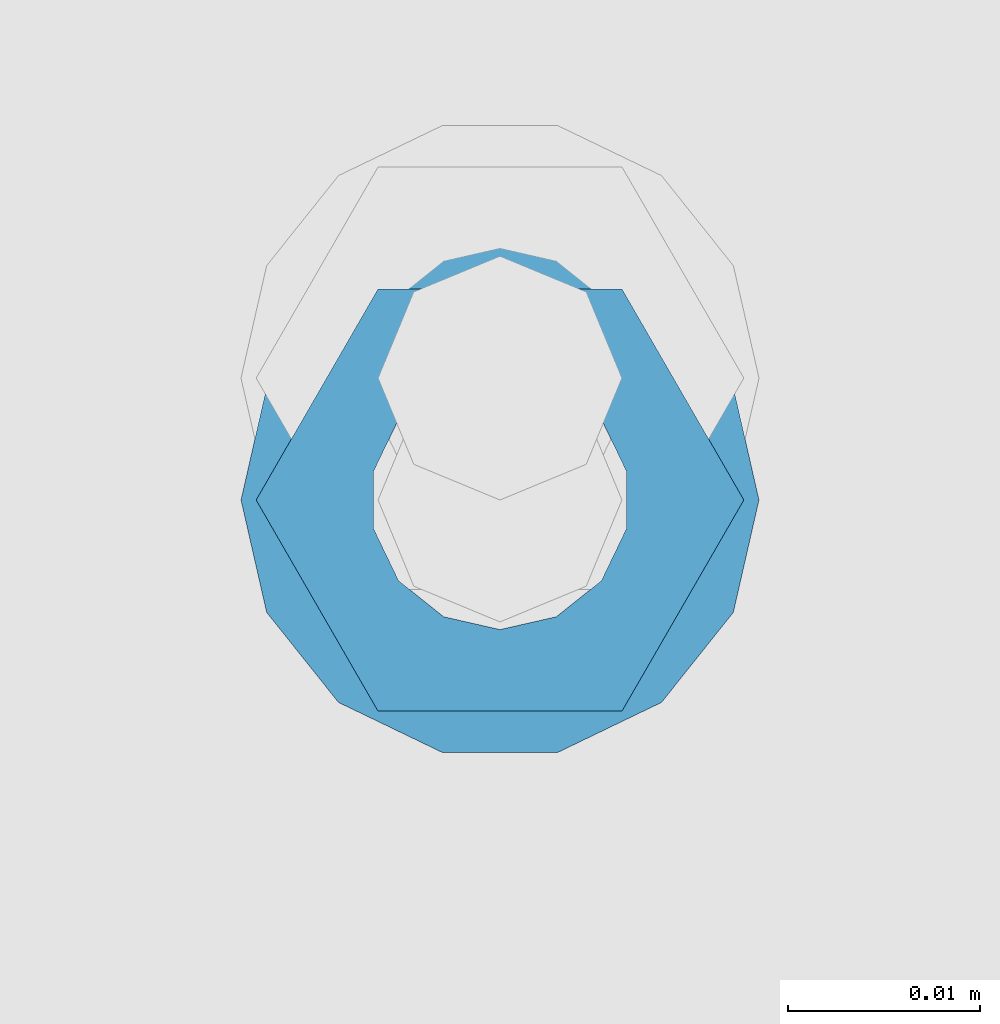
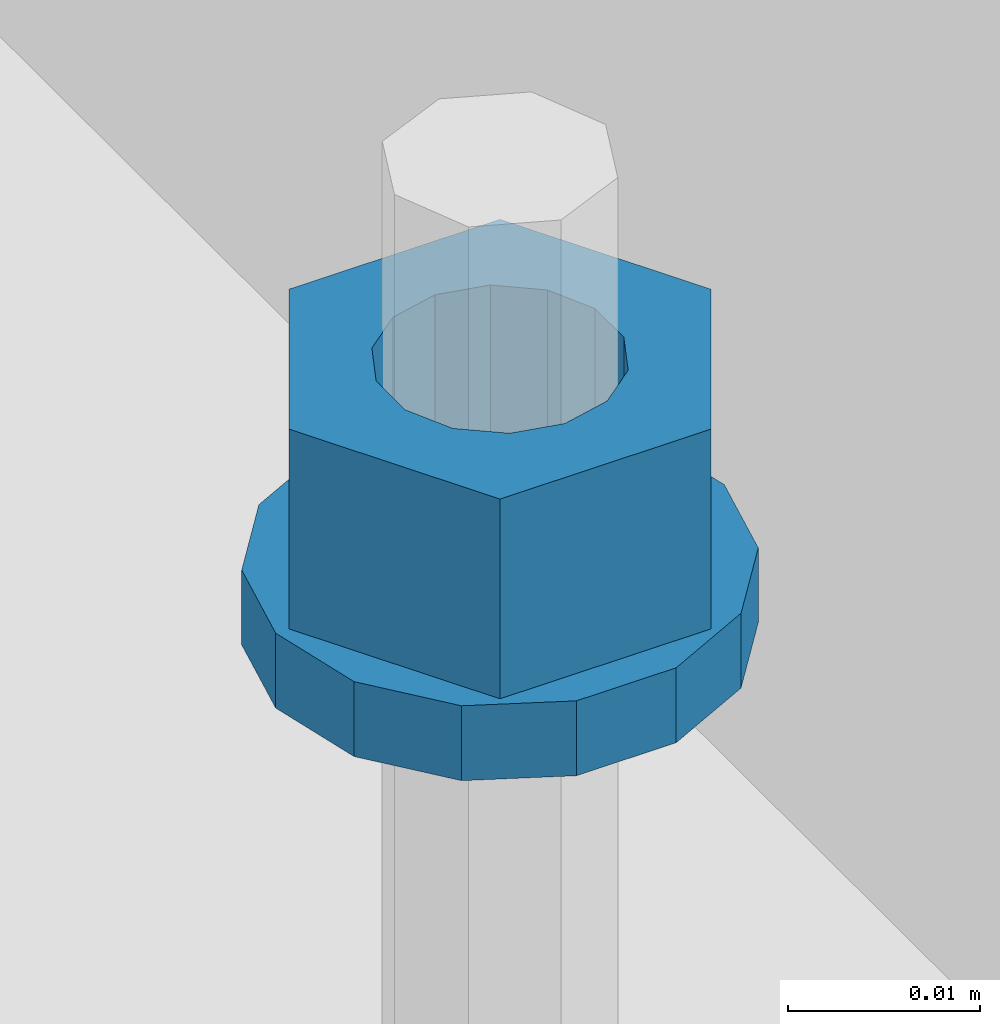
# One storey, part 639 of 1179: 2 columns, 1 element without a shape of its own.
"""IFC2X3 building model written with IfcOpenShell, lengths in millimetres."""

from ifc_helpers import new_model, si_unit, frame, origin_with_axes, place, context, subcontext, project, spatial, faceted_brep, material, type_object, element, aggregate, save


model = new_model("IFC2X3")

# Units and contexts
model_context = context("Model", 3, precision=1e-05, world=origin_with_axes())
body_context = subcontext(model_context, "Body", "Model", "MODEL_VIEW")
ifc_project = project(units=[si_unit("LENGTHUNIT", "METRE", prefix="MILLI"), si_unit("AREAUNIT", "SQUARE_METRE"), si_unit("VOLUMEUNIT", "CUBIC_METRE"), si_unit("MASSUNIT", "GRAM", prefix="KILO"), si_unit("TIMEUNIT", "SECOND"), si_unit("PLANEANGLEUNIT", "RADIAN"), si_unit("SOLIDANGLEUNIT", "STERADIAN"), si_unit("THERMODYNAMICTEMPERATUREUNIT", "DEGREE_CELSIUS"), si_unit("LUMINOUSINTENSITYUNIT", "LUMEN")], contexts=[model_context])

# Site, building, storey
site_placement = place(None, origin_with_axes())
site = spatial("IfcSite", under=ifc_project, at=site_placement, CompositionType="ELEMENT")
building_placement = place(site_placement, origin_with_axes())
building = spatial("IfcBuilding", under=site, at=building_placement, Name="Undefined", CompositionType="ELEMENT")
storey_placement = place(building_placement, origin_with_axes())
storey = spatial("IfcBuildingStorey", under=building, at=storey_placement, Name="Undefined", CompositionType="ELEMENT", Elevation=0.0)

# Assembly, columns
assembly_placement = place(storey_placement, origin_with_axes())
assembly = element("IfcElementAssembly", 1, at=assembly_placement, inside=storey, Name="BEAM", AssemblyPlace="NOTDEFINED", PredefinedType="RIGID_FRAME")
ifc_material = material(Name="STEEL/A307")
column_type_1 = type_object("IfcColumnType", Name="1/2_WASHER", PredefinedType="NOTDEFINED")
column_1_placement = place(assembly_placement, frame((24638.0, 31026.10025, 4235.45), z_axis=(0.0, 1.0, 0.0), x_axis=(0.0, 0.0, 1.0)))
column_1 = element("IfcColumn", 2, at=column_1_placement, type_object=column_type_1, material=ifc_material, Name="WASHER", ObjectType="1/2_WASHER", context=body_context, shape_type="Brep", body=[
    faceted_brep([(0.0, -13.4899997711182, 0.0), (0.0, -12.1540698217868, -5.85309154138758), (4.76249999999891, -12.1540698217868, -5.85309154138758), (4.76249999999891, -13.4899997711182, 0.0), (0.0, -8.41087728436833, -10.5469065195466), (4.76249999999891, -8.41087728436833, -10.5469065195466), (0.0, -3.00180734814057, -13.1517773121896), (4.76249999999891, -3.00180734814057, -13.1517773121896), (0.0, 3.00180734814057, -13.1517773121896), (4.76249999999891, 3.00180734814057, -13.1517773121896), (0.0, 8.41087728436833, -10.5469065195466), (4.76249999999891, 8.41087728436833, -10.5469065195466), (0.0, 12.1540698217868, -5.85309154138758), (4.76249999999891, 12.1540698217868, -5.85309154138758), (0.0, 13.4899997711182, 0.0), (4.76249999999891, 13.4899997711182, 0.0), (0.0, 12.1540698217868, 5.85309154138758), (4.76249999999891, 12.1540698217868, 5.85309154138758), (0.0, 8.41087728436833, 10.5469065195466), (4.76249999999891, 8.41087728436833, 10.5469065195466), (0.0, 3.00180734814057, 13.1517773121896), (4.76249999999891, 3.00180734814057, 13.1517773121896), (0.0, -3.00180734814057, 13.1517773121896), (4.76249999999891, -3.00180734814057, 13.1517773121896), (0.0, -8.41087728436833, 10.5469065195466), (4.76249999999891, -8.41087728436833, 10.5469065195466), (0.0, -12.1540698217868, 5.85309154138758), (4.76249999999891, -12.1540698217868, 5.85309154138758), (0.0, 0.0, 6.75), (0.0, 2.9287152390425, 6.08153985834178), (4.76249999999891, 2.9287152390425, 6.08153985834178), (4.76249999999891, 0.0, 6.75), (0.0, 5.27736250665839, 4.2085561625463), (4.76249999999891, 5.27736250665839, 4.2085561625463), (0.0, 6.58076340722619, 1.50201630420543), (4.76249999999891, 6.58076340722619, 1.50201630420543), (0.0, 6.58076340722619, -1.50201630420543), (4.76249999999891, 6.58076340722619, -1.50201630420543), (0.0, 5.27736250665839, -4.2085561625463), (4.76249999999891, 5.27736250665839, -4.2085561625463), (0.0, 2.9287152390425, -6.08153985834088), (4.76249999999891, 2.9287152390425, -6.08153985834088), (0.0, 0.0, -6.75), (4.76249999999891, 0.0, -6.75), (0.0, -2.9287152390425, -6.08153985834178), (4.76249999999891, -2.9287152390425, -6.08153985834178), (0.0, -5.27736250665839, -4.2085561625463), (4.76249999999891, -5.27736250665839, -4.2085561625463), (0.0, -6.58076340722619, -1.50201630420543), (4.76249999999891, -6.58076340722619, -1.50201630420543), (0.0, -6.58076340722619, 1.50201630420543), (4.76249999999891, -6.58076340722619, 1.50201630420543), (0.0, -5.27736250665839, 4.2085561625463), (4.76249999999891, -5.27736250665839, 4.2085561625463), (0.0, -2.9287152390425, 6.08153985834088), (4.76249999999891, -2.9287152390425, 6.08153985834088)], [[[0, 1, 2, 3]], [[1, 4, 5, 2]], [[4, 6, 7, 5]], [[6, 8, 9, 7]], [[8, 10, 11, 9]], [[10, 12, 13, 11]], [[12, 14, 15, 13]], [[14, 16, 17, 15]], [[16, 18, 19, 17]], [[18, 20, 21, 19]], [[20, 22, 23, 21]], [[22, 24, 25, 23]], [[24, 26, 27, 25]], [[26, 0, 3, 27]], [[28, 29, 30, 31]], [[29, 32, 33, 30]], [[32, 34, 35, 33]], [[34, 36, 37, 35]], [[36, 38, 39, 37]], [[38, 40, 41, 39]], [[40, 42, 43, 41]], [[42, 44, 45, 43]], [[44, 46, 47, 45]], [[46, 48, 49, 47]], [[48, 50, 51, 49]], [[50, 52, 53, 51]], [[52, 54, 55, 53]], [[54, 28, 31, 55]], [[5, 7, 9, 11, 13, 15, 17, 19, 21, 23, 25, 27, 3, 2], [33, 35, 37, 39, 41, 43, 45, 47, 49, 51, 53, 55, 31, 30]], [[26, 24, 22, 20, 18, 16, 14, 12, 10, 8, 6, 4, 1, 0], [54, 52, 50, 48, 46, 44, 42, 40, 38, 36, 34, 32, 29, 28]]]),
])
column_type_2 = type_object("IfcColumnType", Name="1/2_HEAVY_HEX_NUT", PredefinedType="NOTDEFINED")
column_2_placement = place(assembly_placement, frame((24638.0, 31026.10025, 4240.2125), z_axis=(0.0, 1.0, 0.0), x_axis=(0.0, 0.0, 1.0)))
column_2 = element("IfcColumn", 3, at=column_2_placement, type_object=column_type_2, material=ifc_material, Name="NUT", ObjectType="1/2_HEAVY_HEX_NUT", context=body_context, shape_type="Brep", body=[
    faceted_brep([(0.0, -12.7, 0.0), (0.0, -6.34999990463257, -11.0), (12.7000000000007, -6.34999990463257, -11.0), (12.7000000000007, -12.6999998092651, 0.0), (0.0, 6.34999990463257, -11.0), (12.7000000000007, 6.34999990463257, -11.0), (0.0, 12.7, 0.0), (12.7000000000007, 12.6999998092651, 0.0), (0.0, 6.34999990463257, 11.0), (12.7000000000007, 6.34999990463257, 11.0), (0.0, -6.34999990463257, 11.0), (12.7000000000007, -6.34999990463257, 11.0), (0.0, 0.0, 6.75), (0.0, 2.9287152390425, 6.08153985834178), (12.7000000000007, 2.9287152390425, 6.08153985834178), (12.7000000000007, 0.0, 6.75), (0.0, 5.27736250665839, 4.2085561625463), (12.7000000000007, 5.27736250665839, 4.2085561625463), (0.0, 6.58076340722619, 1.50201630420543), (12.7000000000007, 6.58076340722619, 1.50201630420543), (0.0, 6.58076340722619, -1.50201630420543), (12.7000000000007, 6.58076340722619, -1.50201630420543), (0.0, 5.27736250665839, -4.2085561625463), (12.7000000000007, 5.27736250665839, -4.2085561625463), (0.0, 2.9287152390425, -6.08153985834088), (12.7000000000007, 2.9287152390425, -6.08153985834088), (0.0, 0.0, -6.75), (12.7000000000007, 0.0, -6.75), (0.0, -2.9287152390425, -6.08153985834178), (12.7000000000007, -2.9287152390425, -6.08153985834178), (0.0, -5.27736250665839, -4.2085561625463), (12.7000000000007, -5.27736250665839, -4.2085561625463), (0.0, -6.58076340722619, -1.50201630420543), (12.7000000000007, -6.58076340722619, -1.50201630420543), (0.0, -6.58076340722619, 1.50201630420543), (12.7000000000007, -6.58076340722619, 1.50201630420543), (0.0, -5.27736250665839, 4.2085561625463), (12.7000000000007, -5.27736250665839, 4.2085561625463), (0.0, -2.9287152390425, 6.08153985834088), (12.7000000000007, -2.9287152390425, 6.08153985834088)], [[[0, 1, 2, 3]], [[1, 4, 5, 2]], [[4, 6, 7, 5]], [[6, 8, 9, 7]], [[8, 10, 11, 9]], [[10, 0, 3, 11]], [[12, 13, 14, 15]], [[13, 16, 17, 14]], [[16, 18, 19, 17]], [[18, 20, 21, 19]], [[20, 22, 23, 21]], [[22, 24, 25, 23]], [[24, 26, 27, 25]], [[26, 28, 29, 27]], [[28, 30, 31, 29]], [[30, 32, 33, 31]], [[32, 34, 35, 33]], [[34, 36, 37, 35]], [[36, 38, 39, 37]], [[38, 12, 15, 39]], [[5, 7, 9, 11, 3, 2], [17, 19, 21, 23, 25, 27, 29, 31, 33, 35, 37, 39, 15, 14]], [[10, 8, 6, 4, 1, 0], [38, 36, 34, 32, 30, 28, 26, 24, 22, 20, 18, 16, 13, 12]]]),
])
aggregate(assembly, [column_1, column_2])

save(model, "model.ifc")
